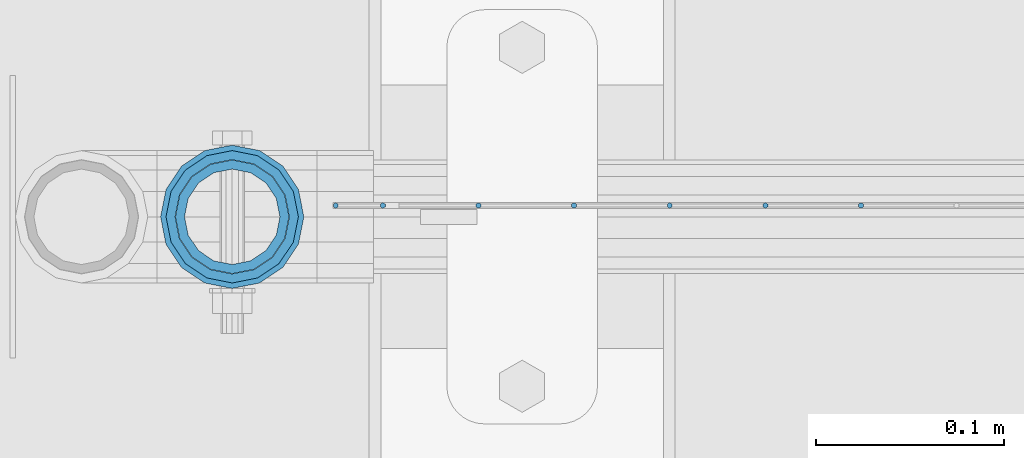
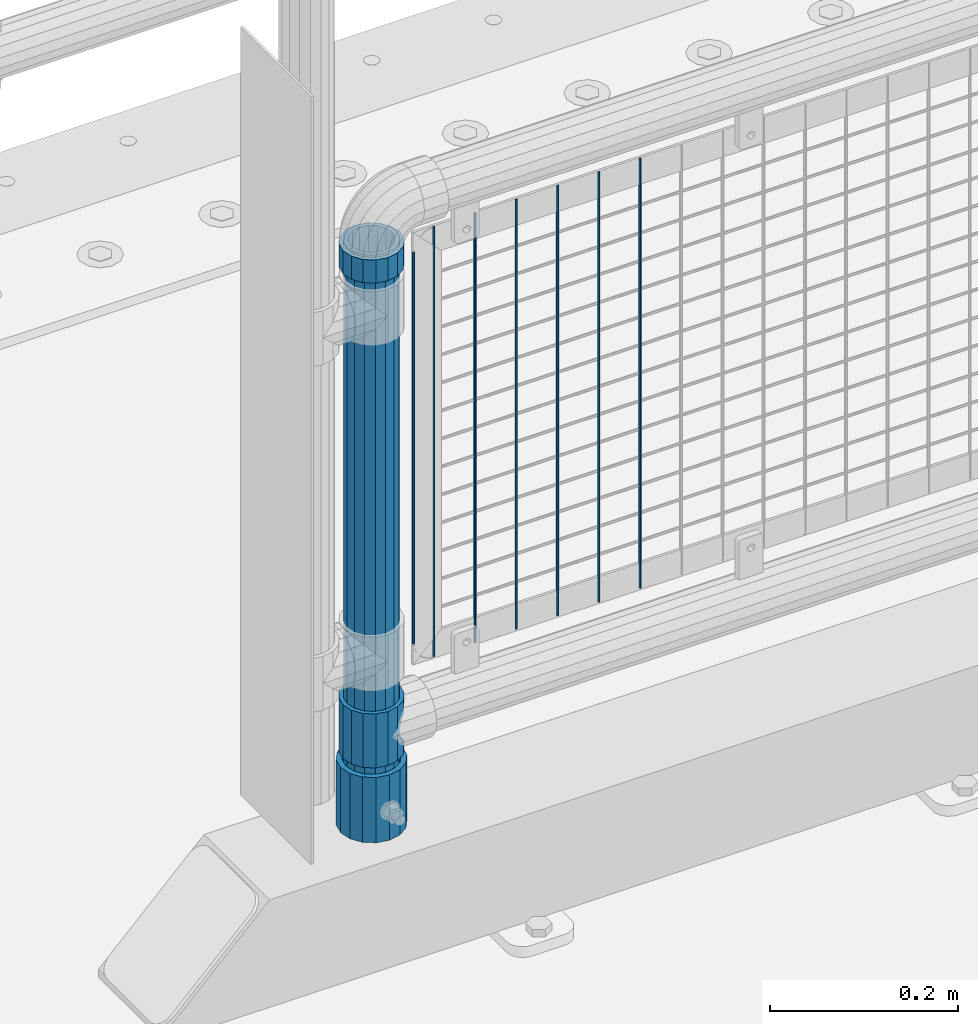
# One storey, part 67 of 270: 11 columns.
"""IFC2X3 building model written with IfcOpenShell, lengths in millimetres."""

from ifc_helpers import new_model, si_unit, frame, origin_with_axes, place, context, subcontext, project, spatial, faceted_brep, material, type_object, element, save


model = new_model("IFC2X3")

# Units and contexts
model_context = context("Model", 3, precision=1e-05, world=origin_with_axes())
body_context = subcontext(model_context, "Body", "Model", "MODEL_VIEW")
ifc_project = project(units=[si_unit("LENGTHUNIT", "METRE", prefix="MILLI"), si_unit("AREAUNIT", "SQUARE_METRE"), si_unit("VOLUMEUNIT", "CUBIC_METRE"), si_unit("MASSUNIT", "GRAM", prefix="KILO"), si_unit("TIMEUNIT", "SECOND"), si_unit("PLANEANGLEUNIT", "RADIAN"), si_unit("SOLIDANGLEUNIT", "STERADIAN"), si_unit("THERMODYNAMICTEMPERATUREUNIT", "DEGREE_CELSIUS"), si_unit("LUMINOUSINTENSITYUNIT", "LUMEN")], contexts=[model_context])

# Site, building, storey
site_placement = place(None, origin_with_axes())
site = spatial("IfcSite", under=ifc_project, at=site_placement, CompositionType="ELEMENT")
building_placement = place(site_placement, origin_with_axes())
building = spatial("IfcBuilding", under=site, at=building_placement, Name="Standard", CompositionType="ELEMENT")
storey_placement = place(building_placement, origin_with_axes())
storey = spatial("IfcBuildingStorey", under=building, at=storey_placement, Name="Undefined", CompositionType="ELEMENT", Elevation=0.0)

# Columns
ifc_material_1 = material()
column_type_1 = type_object("IfcColumnType", PredefinedType="NOTDEFINED")
column_1_placement = place(storey_placement, frame((620.999999804207, -16335.5, 168.019999999998), z_axis=(-1.0, 0.0, 0.0), x_axis=(0.0, 0.0, 1.0)))
element("IfcColumn", 1, at=column_1_placement, inside=storey, type_object=column_type_1, material=ifc_material_1, context=body_context, shape_type="Brep", body=[
    faceted_brep([(0.0, -25.3500000000004, 0.0), (0.0, -23.4203461491616, 9.70102501045403), (760.0, -23.4203461491616, 9.70102501045403), (760.0, -25.3500000000004, 0.0), (0.0, -17.9251569030785, 17.9251569030785), (760.0, -17.9251569030785, 17.9251569030785), (0.0, -9.70102501045585, 23.4203461491597), (760.0, -9.70102501045585, 23.4203461491597), (0.0, 0.0, 25.3499999999985), (760.0, 0.0, 25.3499999999985), (0.0, 9.70102501045585, 23.4203461491597), (760.0, 9.70102501045585, 23.4203461491597), (0.0, 17.9251569030785, 17.9251569030785), (760.0, 17.9251569030785, 17.9251569030785), (0.0, 23.4203461491616, 9.70102501045403), (760.0, 23.4203461491616, 9.70102501045403), (0.0, 25.3500000000004, 0.0), (760.0, 25.3500000000004, 0.0), (0.0, 23.4203461491616, -9.70102501045403), (760.0, 23.4203461491616, -9.70102501045403), (0.0, 17.9251569030785, -17.9251569030785), (760.0, 17.9251569030785, -17.9251569030785), (0.0, 9.70102501045585, -23.4203461491597), (760.0, 9.70102501045585, -23.4203461491597), (0.0, 0.0, -25.3499999999985), (760.0, 0.0, -25.3499999999985), (0.0, -9.70102501045585, -23.4203461491597), (760.0, -9.70102501045585, -23.4203461491597), (0.0, -17.9251569030785, -17.9251569030785), (760.0, -17.9251569030785, -17.9251569030785), (0.0, -23.4203461491616, -9.70102501045403), (760.0, -23.4203461491616, -9.70102501045403), (0.0, -30.1499999999996, 0.0), (0.0, -27.8549679052157, -11.5379054858058), (760.0, -27.8549679052157, -11.5379054858058), (760.0, -30.1499999999996, 0.0), (0.0, -21.3192694527752, -21.3192694527752), (760.0, -21.3192694527752, -21.3192694527752), (0.0, -11.5379054858076, -27.8549679052157), (760.0, -11.5379054858076, -27.8549679052157), (0.0, 0.0, -30.1500000000015), (760.0, 0.0, -30.1500000000015), (0.0, 11.5379054858076, -27.8549679052157), (760.0, 11.5379054858076, -27.8549679052157), (0.0, 21.3192694527752, -21.3192694527752), (760.0, 21.3192694527752, -21.3192694527752), (0.0, 27.8549679052157, -11.5379054858058), (760.0, 27.8549679052157, -11.5379054858058), (0.0, 30.1499999999996, 0.0), (760.0, 30.1499999999996, 0.0), (0.0, 27.8549679052157, 11.5379054858058), (760.0, 27.8549679052157, 11.5379054858058), (0.0, 21.3192694527752, 21.3192694527752), (760.0, 21.3192694527752, 21.3192694527752), (0.0, 11.5379054858076, 27.8549679052157), (760.0, 11.5379054858076, 27.8549679052157), (0.0, 0.0, 30.1500000000015), (760.0, 0.0, 30.1500000000015), (0.0, -11.5379054858076, 27.8549679052157), (760.0, -11.5379054858076, 27.8549679052157), (0.0, -21.3192694527752, 21.3192694527752), (760.0, -21.3192694527752, 21.3192694527752), (0.0, -27.8549679052157, 11.5379054858058), (760.0, -27.8549679052157, 11.5379054858058)], [[[0, 1, 2, 3]], [[1, 4, 5, 2]], [[4, 6, 7, 5]], [[6, 8, 9, 7]], [[8, 10, 11, 9]], [[10, 12, 13, 11]], [[12, 14, 15, 13]], [[14, 16, 17, 15]], [[16, 18, 19, 17]], [[18, 20, 21, 19]], [[20, 22, 23, 21]], [[22, 24, 25, 23]], [[24, 26, 27, 25]], [[26, 28, 29, 27]], [[28, 30, 31, 29]], [[30, 0, 3, 31]], [[32, 33, 34, 35]], [[33, 36, 37, 34]], [[36, 38, 39, 37]], [[38, 40, 41, 39]], [[40, 42, 43, 41]], [[42, 44, 45, 43]], [[44, 46, 47, 45]], [[46, 48, 49, 47]], [[48, 50, 51, 49]], [[50, 52, 53, 51]], [[52, 54, 55, 53]], [[54, 56, 57, 55]], [[56, 58, 59, 57]], [[58, 60, 61, 59]], [[60, 62, 63, 61]], [[62, 32, 35, 63]], [[37, 39, 41, 43, 45, 47, 49, 51, 53, 55, 57, 59, 61, 63, 35, 34], [5, 7, 9, 11, 13, 15, 17, 19, 21, 23, 25, 27, 29, 31, 3, 2]], [[62, 60, 58, 56, 54, 52, 50, 48, 46, 44, 42, 40, 38, 36, 33, 32], [30, 28, 26, 24, 22, 20, 18, 16, 14, 12, 10, 8, 6, 4, 1, 0]]]),
])
column_type_2 = type_object("IfcColumnType", PredefinedType="NOTDEFINED")
column_2_placement = place(storey_placement, frame((620.999999804207, -16335.5, 168.019999999998), z_axis=(0.0, 1.0, 0.0), x_axis=(0.0, 0.0, 1.0)))
element("IfcColumn", 2, at=column_2_placement, inside=storey, type_object=column_type_2, material=ifc_material_1, context=body_context, shape_type="Brep", body=[
    faceted_brep([(0.0, -31.75, 0.0), (0.0, -29.3331751572332, 12.1501989775916), (85.0, -29.3331751572332, 12.1501989775916), (85.0, -31.75, 0.0), (0.0, -22.4506403026717, 22.4506403026735), (85.0, -22.4506403026717, 22.4506403026735), (0.0, -12.1501989775934, 29.3331751572332), (85.0, -12.1501989775934, 29.3331751572332), (0.0, 0.0, 31.75), (85.0, 0.0, 31.75), (0.0, 12.1501989775934, 29.3331751572332), (85.0, 12.1501989775934, 29.3331751572332), (0.0, 22.4506403026717, 22.4506403026735), (85.0, 22.4506403026717, 22.4506403026735), (0.0, 29.3331751572332, 12.1501989775916), (85.0, 29.3331751572332, 12.1501989775916), (0.0, 31.75, 0.0), (85.0, 31.75, 0.0), (0.0, 29.3331751572332, -12.1501989775916), (85.0, 29.3331751572332, -12.1501989775916), (0.0, 22.4506403026717, -22.4506403026735), (85.0, 22.4506403026717, -22.4506403026735), (0.0, 12.1501989775934, -29.3331751572332), (85.0, 12.1501989775934, -29.3331751572332), (0.0, 0.0, -31.75), (85.0, 0.0, -31.75), (0.0, -12.1501989775934, -29.3331751572332), (85.0, -12.1501989775934, -29.3331751572332), (0.0, -22.4506403026717, -22.4506403026735), (85.0, -22.4506403026717, -22.4506403026735), (0.0, -29.3331751572332, -12.1501989775916), (85.0, -29.3331751572332, -12.1501989775916), (0.0, -38.0499999999993, 0.0), (0.0, -35.1536162120537, -14.561104601491), (85.0, -35.1536162120537, -14.561104601491), (85.0, -38.0499999999993, 0.0), (0.0, -26.9054130241493, -26.9054130241475), (85.0, -26.9054130241493, -26.9054130241475), (0.0, -14.5611046014928, -35.1536162120537), (85.0, -14.5611046014928, -35.1536162120537), (0.0, 0.0, -38.0499999999993), (85.0, 0.0, -38.0499999999993), (0.0, 14.5611046014928, -35.1536162120537), (85.0, 14.5611046014928, -35.1536162120537), (0.0, 26.9054130241493, -26.9054130241475), (85.0, 26.9054130241493, -26.9054130241475), (0.0, 35.1536162120537, -14.561104601491), (85.0, 35.1536162120537, -14.561104601491), (0.0, 38.0499999999993, 0.0), (85.0, 38.0499999999993, 0.0), (0.0, 35.1536162120537, 14.561104601491), (85.0, 35.1536162120537, 14.561104601491), (0.0, 26.9054130241493, 26.9054130241475), (85.0, 26.9054130241493, 26.9054130241475), (0.0, 14.5611046014928, 35.1536162120537), (85.0, 14.5611046014928, 35.1536162120537), (0.0, 0.0, 38.0499999999993), (85.0, 0.0, 38.0499999999993), (0.0, -14.5611046014928, 35.1536162120537), (85.0, -14.5611046014928, 35.1536162120537), (0.0, -26.9054130241493, 26.9054130241475), (85.0, -26.9054130241493, 26.9054130241475), (0.0, -35.1536162120537, 14.561104601491), (85.0, -35.1536162120537, 14.561104601491)], [[[0, 1, 2, 3]], [[1, 4, 5, 2]], [[4, 6, 7, 5]], [[6, 8, 9, 7]], [[8, 10, 11, 9]], [[10, 12, 13, 11]], [[12, 14, 15, 13]], [[14, 16, 17, 15]], [[16, 18, 19, 17]], [[18, 20, 21, 19]], [[20, 22, 23, 21]], [[22, 24, 25, 23]], [[24, 26, 27, 25]], [[26, 28, 29, 27]], [[28, 30, 31, 29]], [[30, 0, 3, 31]], [[32, 33, 34, 35]], [[33, 36, 37, 34]], [[36, 38, 39, 37]], [[38, 40, 41, 39]], [[40, 42, 43, 41]], [[42, 44, 45, 43]], [[44, 46, 47, 45]], [[46, 48, 49, 47]], [[48, 50, 51, 49]], [[50, 52, 53, 51]], [[52, 54, 55, 53]], [[54, 56, 57, 55]], [[56, 58, 59, 57]], [[58, 60, 61, 59]], [[60, 62, 63, 61]], [[62, 32, 35, 63]], [[37, 39, 41, 43, 45, 47, 49, 51, 53, 55, 57, 59, 61, 63, 35, 34], [5, 7, 9, 11, 13, 15, 17, 19, 21, 23, 25, 27, 29, 31, 3, 2]], [[62, 60, 58, 56, 54, 52, 50, 48, 46, 44, 42, 40, 38, 36, 33, 32], [30, 28, 26, 24, 22, 20, 18, 16, 14, 12, 10, 8, 6, 4, 1, 0]]]),
])
ifc_material_2 = material(Name="Misc_Undefined")
column_type_3 = type_object("IfcColumnType", PredefinedType="NOTDEFINED")
column_3_placement = place(storey_placement, frame((621.0, -16335.5, 263.52), z_axis=(-1.0, 0.0, 0.0), x_axis=(0.0, 0.0, 1.0)))
element("IfcColumn", 3, at=column_3_placement, inside=storey, type_object=column_type_3, material=ifc_material_2, context=body_context, shape_type="Brep", body=[
    faceted_brep([(63.1897438117183, 11.6144421722802, -32.8397438117208), (63.1897438117183, 11.6144421722802, -28.0397438117179), (56.6106908090125, 21.4606908090118, -21.46069080901), (56.6106908090125, 21.4606908090118, -27.1226768591005), (61.9623795176767, 13.4513226476338, -32.4743655677703), (46.7644421722812, 28.0397438117179, -11.614442172282), (46.7644421722812, 28.0397438117179, -20.0882031229812), (51.5310424080071, 24.8548033587067, -24.8548033587067), (35.1500000000015, 30.35, 0.0), (35.1500000000008, 30.3500000000004, -16.6306603983612), (23.5355578277203, 28.0397438117179, -11.614442172282), (23.5355578277203, 28.0397438117179, -20.0882031229812), (18.7689575919954, 24.8548033587067, -24.8548033587067), (13.689309190989, 21.4606908090118, -21.46069080901), (13.689309190989, 21.4606908090118, -27.1226768591005), (8.33762048232484, 13.4513226476338, -32.4743655677703), (7.11025618828324, 11.6144421722802, -28.0397438117179), (7.11025618828324, 11.6144421722802, -32.8397438117208), (4.80000000000075, 0.0, -30.3499999999985), (4.80000000000075, 0.0, -35.1500000000015), (7.11025618828319, -11.6144421722802, -28.0397438117179), (7.11025618828319, -11.6144421722802, -32.8397438117172), (13.689309190989, -21.4606908090118, -21.46069080901), (13.689309190989, -21.4606908090118, -27.1226768591041), (8.33762048232484, -13.4513226476338, -32.4743655677703), (23.5355578277203, -28.0397438117179, -11.614442172282), (23.5355578277203, -28.0397438117179, -20.0882031229885), (18.7689575919954, -24.8548033587067, -24.8548033587067), (35.1500000000015, -30.35, 0.0), (35.1500000000008, -30.3500000000004, -16.6306603983721), (46.7644421722812, -28.0397438117179, -11.614442172282), (46.7644421722812, -28.0397438117179, -20.0882031229885), (51.5310424080071, -24.8548033587067, -24.8548033587067), (56.6106908090125, -21.4606908090118, -21.46069080901), (56.6106908090125, -21.4606908090118, -27.1226768591041), (61.9623795176767, -13.4513226476338, -32.4743655677703), (63.1897438117183, -11.6144421722802, -28.0397438117179), (63.1897438117183, -11.6144421722802, -32.8397438117172), (65.5000000000008, 0.0, -30.3499999999985), (65.5000000000008, 0.0, -35.1500000000015), (70.2999999999993, -11.6144421722802, -28.0397438117179), (70.2999999999993, 0.0, -30.3499999999985), (70.2999999999993, -21.4606908090118, -21.46069080901), (70.2999999999993, -28.0397438117179, -11.614442172282), (70.2999999999993, -30.3500000000004, 0.0), (0.0, -28.0397438117179, -11.614442172282), (0.0, -30.3500000000004, 0.0), (0.0, -21.4606908090118, -21.46069080901), (0.0, -11.6144421722802, -28.0397438117179), (0.0, 0.0, -30.3499999999985), (0.0, 11.6144421722802, -28.0397438117179), (0.0, 21.4606908090118, -21.46069080901), (0.0, 28.0397438117179, -11.614442172282), (0.0, 30.3500000000004, 0.0), (0.0, -24.8548033587067, -24.8548033587067), (0.0, -13.4513226476338, -32.4743655677703), (0.0, 0.0, -35.1499999999996), (0.0, 13.4513226476338, -32.4743655677703), (0.0, 24.8548033587067, -24.8548033587067), (0.0, -32.4743655677721, 13.4513226476338), (0.0, -35.1499999999996, 0.0), (70.2999999999993, -35.1499999999996, 0.0), (70.2999999999993, -32.4743655677721, 13.4513226476338), (0.0, -24.8548033587067, 24.8548033587067), (70.2999999999993, -24.8548033587067, 24.8548033587067), (0.0, -13.4513226476338, 32.4743655677703), (70.2999999999993, -13.4513226476338, 32.4743655677703), (0.0, 0.0, 35.1499999999996), (70.2999999999993, 0.0, 35.1500000000015), (0.0, 13.4513226476338, 32.4743655677703), (70.2999999999993, 13.4513226476338, 32.4743655677703), (0.0, 24.8548033587067, 24.8548033587067), (70.2999999999993, 24.8548033587067, 24.8548033587067), (0.0, 32.4743655677721, 13.4513226476338), (70.2999999999993, 32.4743655677721, 13.4513226476338), (0.0, 35.1499999999996, 0.0), (70.2999999999993, 35.1499999999996, 0.0), (0.0, 32.4743655677721, -13.4513226476338), (70.2999999999993, 32.4743655677721, -13.4513226476338), (70.2999999999993, 24.8548033587067, -24.8548033587067), (70.2999999999993, 13.4513226476338, -32.4743655677703), (70.2999999999993, 0.0, -35.1500000000015), (70.2999999999993, -13.4513226476338, -32.4743655677703), (70.2999999999993, -24.8548033587067, -24.8548033587067), (70.2999999999993, -32.4743655677721, -13.4513226476338), (0.0, -32.4743655677721, -13.4513226476338), (0.0, 28.0397438117179, 11.614442172282), (0.0, 21.4606908090118, 21.46069080901), (0.0, 11.6144421722802, 28.0397438117179), (0.0, 0.0, 30.3499999999985), (0.0, -11.6144421722802, 28.0397438117179), (0.0, -21.4606908090118, 21.46069080901), (0.0, -28.0397438117179, 11.614442172282), (70.2999999999993, 28.0397438117179, 11.614442172282), (70.2999999999993, 21.4606908090118, 21.46069080901), (70.2999999999993, 11.6144421722802, 28.0397438117179), (70.2999999999993, 0.0, 30.3499999999985), (70.2999999999993, -11.6144421722802, 28.0397438117179), (70.2999999999993, -21.4606908090118, 21.46069080901), (70.2999999999993, -28.0397438117179, 11.614442172282), (70.2999999999993, 30.3500000000004, 0.0), (70.2999999999993, 28.0397438117179, -11.614442172282), (70.2999999999993, 21.4606908090118, -21.46069080901), (70.2999999999993, 11.6144421722802, -28.0397438117179)], [[[0, 1, 2, 3, 4]], [[3, 2, 5, 6, 7]], [[6, 5, 8, 9]], [[9, 8, 10, 11]], [[12, 11, 10, 13, 14]], [[15, 14, 13, 16, 17]], [[17, 16, 18, 19]], [[19, 18, 20, 21]], [[21, 20, 22, 23, 24]], [[23, 22, 25, 26, 27]], [[26, 25, 28, 29]], [[29, 28, 30, 31]], [[32, 31, 30, 33, 34]], [[35, 34, 33, 36, 37]], [[37, 36, 38, 39]], [[39, 38, 1, 0]], [[40, 41, 38, 36]], [[42, 40, 36, 33]], [[43, 42, 33, 30]], [[44, 43, 30, 28]], [[45, 46, 28, 25]], [[47, 45, 25, 22]], [[48, 47, 22, 20]], [[49, 48, 20, 18]], [[50, 49, 18, 16]], [[51, 50, 16, 13]], [[52, 51, 13, 10]], [[53, 52, 10, 8]], [[27, 54, 55, 24, 23]], [[24, 55, 56, 19, 21]], [[56, 57, 15, 17, 19]], [[57, 58, 12, 14, 15]], [[59, 60, 61, 62]], [[63, 59, 62, 64]], [[65, 63, 64, 66]], [[67, 65, 66, 68]], [[69, 67, 68, 70]], [[71, 69, 70, 72]], [[73, 71, 72, 74]], [[75, 73, 74, 76]], [[77, 75, 76, 78]], [[58, 77, 78, 79, 7, 6, 9, 11, 12]], [[7, 79, 80, 4, 3]], [[4, 80, 81, 39, 0]], [[82, 83, 32, 34, 35]], [[81, 82, 35, 37, 39]], [[29, 31, 32, 83, 84, 85, 54, 27, 26]], [[60, 85, 84, 61]], [[59, 63, 65, 67, 69, 71, 73, 75, 77, 58, 57, 56, 55, 54, 85, 60], [45, 47, 48, 49, 50, 51, 52, 53, 86, 87, 88, 89, 90, 91, 92, 46]], [[87, 86, 93, 94]], [[88, 87, 94, 95]], [[89, 88, 95, 96]], [[90, 89, 96, 97]], [[91, 90, 97, 98]], [[92, 91, 98, 99]], [[28, 46, 92, 99, 44]], [[83, 82, 81, 80, 79, 78, 76, 74, 72, 70, 68, 66, 64, 62, 61, 84], [98, 97, 96, 95, 94, 93, 100, 101, 102, 103, 41, 40, 42, 43, 44, 99]], [[86, 53, 8, 100, 93]], [[101, 100, 8, 5]], [[102, 101, 5, 2]], [[103, 102, 2, 1]], [[41, 103, 1, 38]]]),
])
column_4_placement = place(storey_placement, frame((621.0, -16335.5, 894.849999999999), z_axis=(-1.0, 0.0, 0.0), x_axis=(0.0, 0.0, 1.0)))
element("IfcColumn", 4, at=column_4_placement, inside=storey, type_object=column_type_3, material=ifc_material_2, context=body_context, shape_type="Brep", body=[
    faceted_brep([(0.0, -30.3500000000004, 0.0), (0.0, -28.0397438117179, 11.614442172282), (30.0, -28.0397438117179, 11.6144421722805), (30.0, -30.3500000000004, 0.0), (0.0, -21.4606908090118, 21.46069080901), (30.0, -21.4606908090118, 21.4606908090117), (0.0, -11.6144421722802, 28.0397438117179), (30.0, -11.6144421722802, 28.0397438117176), (0.0, 0.0, 30.3499999999985), (30.0, 0.0, 30.35), (0.0, 11.6144421722802, 28.0397438117179), (30.0, 11.6144421722802, 28.0397438117176), (0.0, 21.4606908090118, 21.46069080901), (30.0, 21.4606908090118, 21.4606908090117), (0.0, 28.0397438117179, 11.614442172282), (30.0, 28.0397438117179, 11.6144421722805), (0.0, 30.3500000000004, 0.0), (30.0, 30.3500000000004, 0.0), (0.0, 28.0397438117179, -11.614442172282), (30.0, 28.0397438117179, -11.6144421722805), (0.0, 21.4606908090118, -21.46069080901), (30.0, 21.4606908090118, -21.4606908090117), (0.0, 11.6144421722802, -28.0397438117179), (30.0, 11.6144421722802, -28.0397438117176), (0.0, 0.0, -30.3499999999985), (30.0, 0.0, -30.35), (0.0, -11.6144421722802, -28.0397438117179), (30.0, -11.6144421722802, -28.0397438117176), (0.0, -21.4606908090118, -21.46069080901), (30.0, -21.4606908090118, -21.4606908090117), (0.0, -28.0397438117179, -11.614442172282), (30.0, -28.0397438117179, -11.6144421722805), (0.0, -35.1499999999996, 0.0), (0.0, -32.4743655677721, -13.4513226476338), (30.0, -32.4743655677721, -13.4513226476329), (30.0, -35.1499999999996, 0.0), (0.0, -24.8548033587067, -24.8548033587067), (30.0, -24.8548033587067, -24.8548033587072), (0.0, -13.4513226476338, -32.4743655677703), (30.0, -13.4513226476338, -32.4743655677718), (0.0, 0.0, -35.1499999999996), (30.0, 0.0, -35.15), (0.0, 13.4513226476338, -32.4743655677703), (30.0, 13.4513226476338, -32.4743655677718), (0.0, 24.8548033587067, -24.8548033587067), (30.0, 24.8548033587067, -24.8548033587072), (0.0, 32.4743655677721, -13.4513226476338), (30.0, 32.4743655677721, -13.4513226476329), (0.0, 35.1499999999996, 0.0), (30.0, 35.1499999999996, 0.0), (0.0, 32.4743655677721, 13.4513226476338), (30.0, 32.4743655677721, 13.4513226476329), (0.0, 24.8548033587067, 24.8548033587067), (30.0, 24.8548033587067, 24.8548033587072), (0.0, 13.4513226476338, 32.4743655677703), (30.0, 13.4513226476338, 32.4743655677718), (0.0, 0.0, 35.1499999999996), (30.0, 0.0, 35.15), (0.0, -13.4513226476338, 32.4743655677703), (30.0, -13.4513226476338, 32.4743655677718), (0.0, -24.8548033587067, 24.8548033587067), (30.0, -24.8548033587067, 24.8548033587072), (0.0, -32.4743655677721, 13.4513226476338), (30.0, -32.4743655677721, 13.4513226476329)], [[[0, 1, 2, 3]], [[1, 4, 5, 2]], [[4, 6, 7, 5]], [[6, 8, 9, 7]], [[8, 10, 11, 9]], [[10, 12, 13, 11]], [[12, 14, 15, 13]], [[14, 16, 17, 15]], [[16, 18, 19, 17]], [[18, 20, 21, 19]], [[20, 22, 23, 21]], [[22, 24, 25, 23]], [[24, 26, 27, 25]], [[26, 28, 29, 27]], [[28, 30, 31, 29]], [[30, 0, 3, 31]], [[32, 33, 34, 35]], [[33, 36, 37, 34]], [[36, 38, 39, 37]], [[38, 40, 41, 39]], [[40, 42, 43, 41]], [[42, 44, 45, 43]], [[44, 46, 47, 45]], [[46, 48, 49, 47]], [[48, 50, 51, 49]], [[50, 52, 53, 51]], [[52, 54, 55, 53]], [[54, 56, 57, 55]], [[56, 58, 59, 57]], [[58, 60, 61, 59]], [[60, 62, 63, 61]], [[62, 32, 35, 63]], [[37, 39, 41, 43, 45, 47, 49, 51, 53, 55, 57, 59, 61, 63, 35, 34], [5, 7, 9, 11, 13, 15, 17, 19, 21, 23, 25, 27, 29, 31, 3, 2]], [[62, 60, 58, 56, 54, 52, 50, 48, 46, 44, 42, 40, 38, 36, 33, 32], [30, 28, 26, 24, 22, 20, 18, 16, 14, 12, 10, 8, 6, 4, 1, 0]]]),
])
column_type_4 = type_object("IfcColumnType", Name="D3", PredefinedType="NOTDEFINED")
for number, where, z_axis, x_axis in (
    (5, (954.965, -16329.5, 353.02), (-1.0, 0.0, 0.0), (0.0, 0.0, 1.0)),
    (6, (904.172, -16329.5, 353.02), (-1.0, 0.0, 0.0), (0.0, 0.0, 1.0)),
    (7, (853.379, -16329.5, 353.02), (-1.0, 0.0, 0.0), (0.0, 0.0, 1.0)),
    (8, (802.586, -16329.5, 353.02), (-1.0, 0.0, 0.0), (0.0, 0.0, 1.0)),
    (9, (751.793, -16329.5, 353.02), (-1.0, 0.0, 0.0), (0.0, 0.0, 1.0)),
):
    element("IfcColumn", number, at=place(storey_placement, frame(where, z_axis=z_axis, x_axis=x_axis)), inside=storey, type_object=column_type_4, material=ifc_material_2, ObjectType="D3", context=body_context, shape_type="Brep", body=[
        faceted_brep([(0.0, -1.5, 0.0), (0.0, -0.75, -1.29903810567669), (560.0, -0.75, -1.29903810567703), (560.0, -1.5, 0.0), (0.0, 0.75, -1.29903810567669), (560.0, 0.75, -1.29903810567703), (0.0, 1.5, 0.0), (560.0, 1.5, 0.0), (0.0, 0.75, 1.29903810567669), (560.0, 0.75, 1.29903810567703), (0.0, -0.75, 1.29903810567669), (560.0, -0.75, 1.29903810567703)], [[[0, 1, 2, 3]], [[1, 4, 5, 2]], [[4, 6, 7, 5]], [[6, 8, 9, 7]], [[8, 10, 11, 9]], [[10, 0, 3, 11]], [[5, 7, 9, 11, 3, 2]], [[10, 8, 6, 4, 1, 0]]]),
    ])
column_5_placement = place(storey_placement, frame((676.0, -16329.5, 378.02), z_axis=(-1.0, 0.0, 0.0), x_axis=(0.0, 0.0, 1.0)))
element("IfcColumn", 10, at=column_5_placement, inside=storey, type_object=column_type_4, material=ifc_material_2, ObjectType="D3", context=body_context, shape_type="Brep", body=[
    faceted_brep([(0.0, -1.5, 0.0), (0.0, -0.75, -1.29903810567669), (510.0, -0.75, -1.29903810567703), (510.0, -1.5, 0.0), (0.0, 0.75, -1.29903810567669), (510.0, 0.75, -1.29903810567703), (0.0, 1.5, 0.0), (510.0, 1.5, 0.0), (0.0, 0.75, 1.29903810567669), (510.0, 0.75, 1.29903810567703), (0.0, -0.75, 1.29903810567669), (510.0, -0.75, 1.29903810567703)], [[[0, 1, 2, 3]], [[1, 4, 5, 2]], [[4, 6, 7, 5]], [[6, 8, 9, 7]], [[8, 10, 11, 9]], [[10, 0, 3, 11]], [[5, 7, 9, 11, 3, 2]], [[10, 8, 6, 4, 1, 0]]]),
])
column_6_placement = place(storey_placement, frame((701.0, -16329.5, 353.02), z_axis=(-1.0, 0.0, 0.0), x_axis=(0.0, 0.0, 1.0)))
element("IfcColumn", 11, at=column_6_placement, inside=storey, type_object=column_type_4, material=ifc_material_2, ObjectType="D3", context=body_context, shape_type="Brep", body=[
    faceted_brep([(0.0, -1.5, 0.0), (0.0, -0.75, -1.29903810567669), (560.0, -0.75, -1.29903810567703), (560.0, -1.5, 0.0), (0.0, 0.75, -1.29903810567669), (560.0, 0.75, -1.29903810567703), (0.0, 1.5, 0.0), (560.0, 1.5, 0.0), (0.0, 0.75, 1.29903810567669), (560.0, 0.75, 1.29903810567703), (0.0, -0.75, 1.29903810567669), (560.0, -0.75, 1.29903810567703)], [[[0, 1, 2, 3]], [[1, 4, 5, 2]], [[4, 6, 7, 5]], [[6, 8, 9, 7]], [[8, 10, 11, 9]], [[10, 0, 3, 11]], [[5, 7, 9, 11, 3, 2]], [[10, 8, 6, 4, 1, 0]]]),
])

save(model, "model.ifc")
